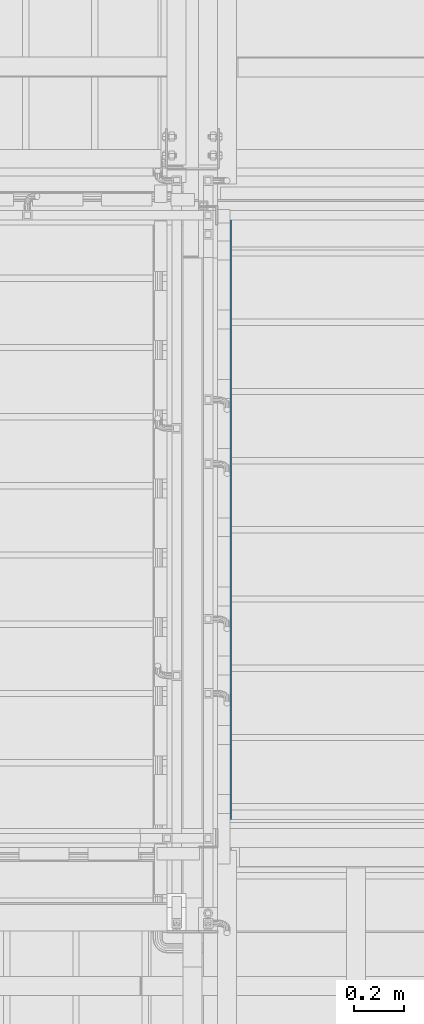
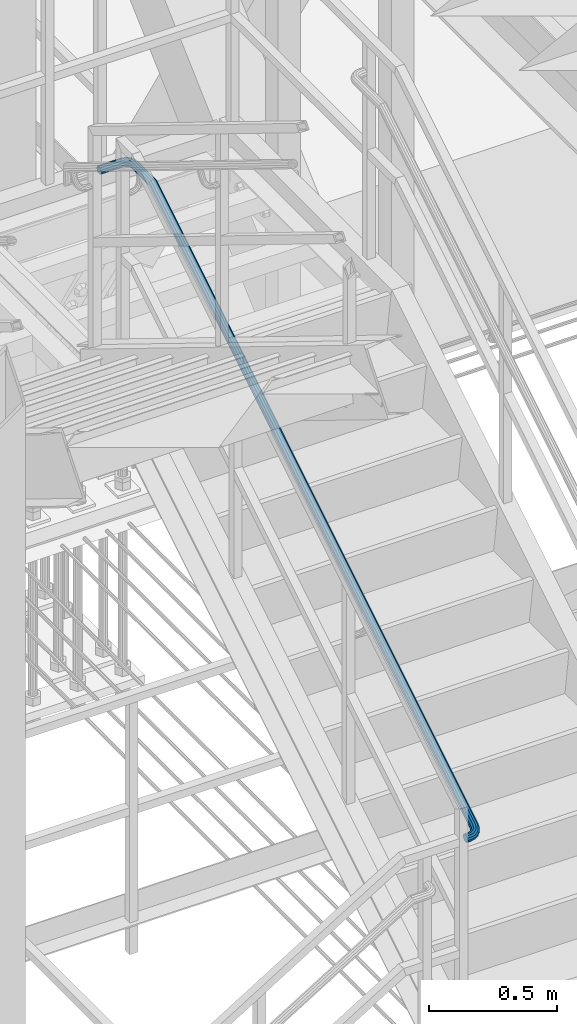
# One storey, part 1767 of 3843: 1 beam, 1 element without a shape of its own.
"""IFC2X3 building model written with IfcOpenShell, lengths in millimetres."""

import ifcopenshell
import ifcopenshell.guid

model = None  # the IFC model being written
_history = None  # IfcOwnerHistory: only IFC2X3 demands one
_inside = {}  # id of a spatial element -> (the spatial element, [elements in it])
_under = {}  # id of a project, library or spatial element -> (it, [spatial elements below it])
_declared = {}  # id of a project -> (the project, [libraries it declares])
_typed = {}  # id of a type object -> (the type object, [elements of that type])
_made_of = {}  # id of a material, layer set ... -> (it, [elements and type objects made of it])


def new_model(schema):
    """Start an empty IFC model of exactly this schema.

    Asked for "IFC4X3", IfcOpenShell would pick the latest addendum, in which some entities
    have other attributes; the version numbers below select the first issue.
    IFC2X3 requires an IfcOwnerHistory on every rooted entity: one is made here for all.
    """
    global model, _history
    if schema == "IFC4X3":
        model = ifcopenshell.file(schema_version=(4, 3, 0, 0))
    else:
        model = ifcopenshell.file(schema=schema)
    _inside.clear()
    _under.clear()
    _declared.clear()
    _typed.clear()
    _made_of.clear()
    _history = None
    if model.schema == "IFC2X3":
        org = make("IfcOrganization", Name="unknown")
        user = make(
            "IfcPersonAndOrganization",
            ThePerson=make("IfcPerson", FamilyName="unknown"),
            TheOrganization=org,
        )
        app = make(
            "IfcApplication",
            ApplicationDeveloper=org,
            Version="unknown",
            ApplicationFullName="unknown",
            ApplicationIdentifier="unknown",
        )
        _history = make(
            "IfcOwnerHistory",
            OwningUser=user,
            OwningApplication=app,
            ChangeAction="ADDED",
            CreationDate=0,
        )
    return model


def make(cls, **values):
    """One entity of the class cls with the attributes given. An attribute that is None is left unset."""
    return model.create_entity(
        cls, **{name: value for name, value in values.items() if value is not None}
    )


def rooted(cls, **values):
    """An entity with a GlobalId (a new one), such as an element, a storey or a relation."""
    return make(cls, GlobalId=ifcopenshell.guid.new(), OwnerHistory=_history, **values)


def si_unit(unit_type, name, prefix=None):
    """IfcSIUnit, for example si_unit("LENGTHUNIT", "METRE", prefix="MILLI")."""
    return make("IfcSIUnit", UnitType=unit_type, Prefix=prefix, Name=name)


def assignment(units):
    """IfcUnitAssignment: the units of a project."""
    return None if units is None else make("IfcUnitAssignment", Units=units)


def point(xyz):
    """IfcCartesianPoint."""
    return None if xyz is None else make("IfcCartesianPoint", Coordinates=xyz)


def direction(xyz):
    """IfcDirection."""
    return None if xyz is None else make("IfcDirection", DirectionRatios=xyz)


def frame(location, z_axis=None, x_axis=None):
    """IfcAxis2Placement3D, a coordinate frame: its origin and axes. An axis left out is left unset."""
    return make(
        "IfcAxis2Placement3D",
        Location=point(location),
        Axis=direction(z_axis),
        RefDirection=direction(x_axis),
    )


def origin_with_axes():
    """The frame at (0, 0, 0) with the z axis (0, 0, 1) and the x axis (1, 0, 0) written out."""
    return frame((0.0, 0.0, 0.0), z_axis=(0.0, 0.0, 1.0), x_axis=(1.0, 0.0, 0.0))


def place(relative_to, where):
    """IfcLocalPlacement: puts the frame where relative to a parent placement (None: the world)."""
    return make(
        "IfcLocalPlacement", PlacementRelTo=relative_to, RelativePlacement=where
    )


def context(
    kind, dimensions, precision=None, world=None, true_north=None, identifier=None
):
    """IfcGeometricRepresentationContext, for example the 3D "Model" context."""
    return make(
        "IfcGeometricRepresentationContext",
        ContextIdentifier=identifier,
        ContextType=kind,
        CoordinateSpaceDimension=dimensions,
        Precision=precision,
        WorldCoordinateSystem=world,
        TrueNorth=true_north,
    )


def subcontext(parent, identifier, kind, view, scale=None):
    """IfcGeometricRepresentationSubContext, for example "Body" below "Model"."""
    return make(
        "IfcGeometricRepresentationSubContext",
        ContextIdentifier=identifier,
        ContextType=kind,
        ParentContext=parent,
        TargetScale=scale,
        TargetView=view,
    )


def project(units=None, contexts=None):
    """IfcProject with its units and contexts."""
    return rooted(
        "IfcProject",
        Name="project",
        RepresentationContexts=contexts,
        UnitsInContext=assignment(units),
    )


def spatial(cls, under=None, at=None, **own):
    """A site, building, storey or space (cls), placed at a placement, below another one or the project."""
    s = rooted(cls, ObjectPlacement=at, **own)
    if under is not None:
        _under.setdefault(under.id(), (under, []))[1].append(s)
    return s


def faces_of(points, faces, orient=None, outer=None):
    """IfcFace entities. A face is a list of loops; a loop is a list of indices into points, from 0.

    orient and outer hold one flag for each loop. By default every Orientation is true, the
    first loop of a face is its IfcFaceOuterBound and the others are IfcFaceBound.
    """
    made = []
    for i, loops in enumerate(faces):
        bounds = []
        for j, loop in enumerate(loops):
            is_outer = j == 0 if outer is None else outer[i][j]
            bounds.append(
                make(
                    "IfcFaceOuterBound" if is_outer else "IfcFaceBound",
                    Bound=make("IfcPolyLoop", Polygon=[points[k] for k in loop]),
                    Orientation=True if orient is None else orient[i][j],
                )
            )
        made.append(make("IfcFace", Bounds=bounds))
    return made


def faceted_brep(points, faces, orient=None, outer=None, voids=None):
    """IfcFacetedBrep: a solid bounded by flat faces; with voids (closed shells), ...WithVoids."""
    shared = [point(p) for p in points]
    hull = make("IfcClosedShell", CfsFaces=faces_of(shared, faces, orient, outer))
    if voids is None:
        return make("IfcFacetedBrep", Outer=hull)
    return make(
        "IfcFacetedBrepWithVoids",
        Outer=hull,
        Voids=[
            make(cls, CfsFaces=faces_of(shared, fs, o, b)) for cls, fs, o, b in voids
        ],
    )


def shape(context_of_items, identifier, shape_type, items):
    """IfcShapeRepresentation: the items that make up one representation, for example the "Body"."""
    return make(
        "IfcShapeRepresentation",
        ContextOfItems=context_of_items,
        RepresentationIdentifier=identifier,
        RepresentationType=shape_type,
        Items=items,
    )


def material(Name=None, Category=None):
    """IfcMaterial."""
    return make("IfcMaterial", Name=Name, Category=Category)


def made_of(thing, what):
    """Note that an element or type object is made of a material, layer set ...; save() writes the relation."""
    if what is not None:
        _made_of.setdefault(what.id(), (what, []))[1].append(thing)
    return thing


def type_object(cls, material=None, **own):
    """A type object (cls), such as IfcWallType, which elements share."""
    return made_of(rooted(cls, **own), material)


def element(
    cls,
    number,
    at=None,
    inside=None,
    cuts=None,
    type_object=None,
    material=None,
    context=None,
    identifier="Body",
    shape_type=None,
    held_by="IfcProductDefinitionShape",
    body=None,
    shapes=None,
    **own,
):
    """One element of the class cls, such as IfcWall. Its Tag is "e" and its number.

    at: its placement. inside: the storey or other place that contains it. cuts: it is an
    opening in that element (IfcRelVoidsElement). A single representation is given by context,
    identifier, shape_type and body (its items); several are given by shapes. held_by: the class
    of the entity that holds the representations. save() writes the other relations.
    """
    e = rooted(cls, Tag="e%d" % number, ObjectPlacement=at, **own)
    if body is not None:
        shapes = [shape(context, identifier, shape_type, body)]
    if shapes is not None:
        e.Representation = make(held_by, Representations=shapes)
    if inside is not None:
        _inside.setdefault(inside.id(), (inside, []))[1].append(e)
    if cuts is not None:
        rooted(
            "IfcRelVoidsElement", RelatingBuildingElement=cuts, RelatedOpeningElement=e
        )
    if type_object is not None:
        _typed.setdefault(type_object.id(), (type_object, []))[1].append(e)
    return made_of(e, material)


def aggregate(whole, parts):
    """IfcRelAggregates: a whole, such as a stair, and the parts it consists of."""
    return rooted("IfcRelAggregates", RelatingObject=whole, RelatedObjects=parts)


def save(model, path):
    """Write the relations noted so far, then the file.

    IfcRelAggregates (storeys below a building ...), IfcRelContainedInSpatialStructure (elements
    in a storey), IfcRelDefinesByType, IfcRelAssociatesMaterial and IfcRelDeclares: one each for
    every whole, place, type object, material and project.
    """
    for whole, parts in _under.values():
        aggregate(whole, parts)
    for where, things in _inside.values():
        rooted(
            "IfcRelContainedInSpatialStructure",
            RelatedElements=things,
            RelatingStructure=where,
        )
    for kind, things in _typed.values():
        rooted("IfcRelDefinesByType", RelatedObjects=things, RelatingType=kind)
    for what, things in _made_of.values():
        rooted("IfcRelAssociatesMaterial", RelatedObjects=things, RelatingMaterial=what)
    for by, libraries in _declared.values():
        rooted("IfcRelDeclares", RelatingContext=by, RelatedDefinitions=libraries)
    model.write(path)


model = new_model("IFC2X3")

# Units and contexts
model_context = context("Model", 3, precision=1e-05, world=origin_with_axes())
body_context = subcontext(model_context, "Body", "Model", "MODEL_VIEW")
ifc_project = project(units=[si_unit("LENGTHUNIT", "METRE", prefix="MILLI"), si_unit("AREAUNIT", "SQUARE_METRE"), si_unit("VOLUMEUNIT", "CUBIC_METRE"), si_unit("MASSUNIT", "GRAM", prefix="KILO"), si_unit("TIMEUNIT", "SECOND"), si_unit("PLANEANGLEUNIT", "RADIAN"), si_unit("SOLIDANGLEUNIT", "STERADIAN"), si_unit("THERMODYNAMICTEMPERATUREUNIT", "DEGREE_CELSIUS"), si_unit("LUMINOUSINTENSITYUNIT", "LUMEN")], contexts=[model_context])

# Site, building, storey
site_placement = place(None, origin_with_axes())
site = spatial("IfcSite", under=ifc_project, at=site_placement, CompositionType="ELEMENT")
building_placement = place(site_placement, origin_with_axes())
building = spatial("IfcBuilding", under=site, at=building_placement, Name="Undefined", CompositionType="ELEMENT")
storey_placement = place(building_placement, origin_with_axes())
storey = spatial("IfcBuildingStorey", under=building, at=storey_placement, Name="Undefined", CompositionType="ELEMENT", Elevation=0.0)

# Assembly, beam
assembly_placement = place(storey_placement, origin_with_axes())
assembly = element("IfcElementAssembly", 1, at=assembly_placement, inside=storey, Name="RAIL", AssemblyPlace="NOTDEFINED", PredefinedType="RIGID_FRAME")
ifc_material = material(Name="STEEL/A513")
beam_type = type_object("IfcBeamType", PredefinedType="NOTDEFINED")
beam_placement = place(assembly_placement, frame((54463.95, 19202.4000001452, 32402.584613986), z_axis=(0.0, 0.0, 1.0), x_axis=(1.0, 0.0, 0.0)))
beam = element("IfcBeam", 2, at=beam_placement, type_object=beam_type, material=ifc_material, Name="GRAB RAIL", context=body_context, shape_type="Brep", body=[
    faceted_brep([(0.0, -19.0500000000029, 0.0), (0.0, -16.4977839420972, -9.52500000000146), (19.0500015258804, -16.4977839420972, -9.52500000000146), (19.0500015258804, -19.0500000000029, 0.0), (0.0, -9.52500000000146, -16.4977839420972), (19.0500015258804, -9.52500000000146, -16.4977839420972), (0.0, 0.0, -19.0499989999989), (19.0500015258804, 0.0, -19.0500000000029), (0.0, 9.52500000000146, -16.4977839420972), (19.0500015258804, 9.52500000000146, -16.4977839420972), (0.0, 16.4977839420972, -9.52500000000146), (19.0500015258804, 16.4977839420972, -9.52500000000146), (0.0, 19.0500000000029, 0.0), (19.0500015258804, 19.0500000000029, 0.0), (0.0, 16.4977839420972, 9.52500000000146), (19.0500015258804, 16.4977839420972, 9.52500000000146), (0.0, 9.52500000000146, 16.4977839420972), (19.0500015258804, 9.52500000000146, 16.4977839420972), (0.0, 0.0, 19.0499989999989), (19.0500015258804, 0.0, 19.0500000000029), (0.0, -9.52500000000146, 16.4977839420972), (19.0500015258804, -9.52500000000146, 16.4977839420972), (0.0, -16.4977839420972, 9.52500000000146), (19.0500015258804, -16.4977839420972, 9.52500000000146), (0.0, -15.875, 0.0), (0.0, -13.7481532850798, 7.9375), (19.0500015258804, -13.7481532850798, 7.9375), (19.0500015258804, -15.875, 0.0), (0.0, -7.9375, 13.7481532850798), (19.0500015258804, -7.9375, 13.7481532850798), (0.0, 0.0, 15.875), (19.0500015258804, 0.0, 15.875), (0.0, 7.9375, 13.7481532850798), (19.0500015258804, 7.9375, 13.7481532850798), (0.0, 13.7481532850798, 7.9375), (19.0500015258804, 13.7481532850798, 7.9375), (0.0, 15.875, 0.0), (19.0500015258804, 15.875, 0.0), (0.0, 13.7481532850798, -7.9375), (19.0500015258804, 13.7481532850798, -7.9375), (0.0, 7.9375, -13.7481532850798), (19.0500015258804, 7.9375, -13.7481532850798), (0.0, 0.0, -15.875), (19.0500015258804, 0.0, -15.875), (0.0, -7.9375, -13.7481532850798), (19.0500015258804, -7.9375, -13.7481532850798), (0.0, -13.7481532850798, -7.9375), (19.0500015258804, -13.7481532850798, -7.9375), (35.8370683576213, -16.785602193122, 1.39347557251313), (33.6227625831598, -14.5320725698184, 10.7346685359589), (30.658409666401, -7.95914849072506, 17.4613848702174), (27.7383055774699, 1.17196034525477, 19.7712063658182), (25.6448898488088, 10.4145806995184, 17.0452182183471), (24.9390915343392, 17.2921599121983, 10.0138467504985), (25.8100287224443, 19.9618561873722, 0.56114226876889), (28.0243344969058, 17.7083265640686, -8.7800506946769), (30.9886874136646, 11.1354024849788, -15.5067670289391), (33.9087915025957, 2.00429364899537, -17.8165885245362), (36.0022072312495, -7.23832670526826, -15.0906003770651), (36.7080055457191, -14.1159059179481, -8.05922890922011), (35.7272627114362, -11.4985670987699, -6.55313927090901), (35.1390974493843, -5.76725108820392, -12.412615494115), (33.3945843421679, 1.93493254035275, -14.6842722836736), (30.9611642680611, 9.54418990366685, -12.7594210373427), (28.4908701707609, 15.0216266362477, -7.15382409212543), (26.645615358706, 16.8995679889958, 0.630503377415152), (25.9198343686221, 14.67482109302, 8.50775711219103), (26.5079996306813, 8.94350508245407, 14.367233335397), (28.2525127378976, 1.2413214538974, 16.6388901249557), (30.6859328120045, -6.3679359094167, 14.7140388786211), (33.1562269093047, -11.8453726419939, 9.10844193340381), (35.0014817213523, -13.7233139947457, 1.32411446386686), (47.3130995891261, 7.82098036889511, -14.2370890070451), (51.2950129292367, -0.602142335348617, -11.0067946137497), (41.758731545051, 15.8089725243517, -12.6307239297494), (36.1201972288836, 21.221458083819, -6.618123607077), (31.9083373571411, 22.6081659125957, 2.18964056010009), (30.2517163810844, 19.5975287678193, 11.4325352760679), (31.594224553417, 12.9962444411394, 18.6339343659492), (35.5761378935276, 4.5731217368957, 21.8642287592447), (41.1305059376027, -3.41487041856089, 20.2578636819526), (46.7690402537701, -8.82735597802821, 14.2452633592802), (50.9809001255198, -10.2140638068013, 5.43749919210313), (52.6375211015693, -7.20342666202851, -3.80539552386472), (49.3915198948162, -7.47887799685486, 5.16684430610258), (50.7720373748598, -4.9700137095424, -2.53556795720215), (45.8816366683604, -6.32328813954155, 12.5066477787514), (41.1828580715519, -1.81288350664909, 17.517148047642), (36.5542180348275, 4.84377662289626, 18.8557856120533), (33.2359569180626, 11.8630455430975, 16.1638736176428), (32.1172001077866, 17.3641158153332, 10.1627077094054), (33.4977175878375, 19.8729801026457, 2.46029544610064), (37.0076008142933, 18.7173902453324, -4.87950802654814), (41.7063794110945, 14.2069856124399, -9.89000829544239), (46.3350194478262, 7.55032548289455, -11.2286458598537), (49.6532805645911, 0.531056562696904, -8.5367338654396), (57.950818716643, 16.8806823363084, -8.66188780013181), (63.4314522468558, 9.7339571466182, -4.64611801380306), (50.3058869611341, 23.0882285199878, -8.1511817816463), (42.5451102704028, 26.6932887107578, -3.25084322356633), (36.7479824913753, 26.7298899418383, 4.72608611482792), (34.4678393308568, 23.1882249429182, 13.642194459233), (36.3156433073382, 17.0172799903194, 21.1084177791417), (41.796276837551, 9.87055480062918, 25.1241875654705), (49.4412085930599, 3.66300861694981, 24.6134815469813), (57.2019852837911, 0.0579484261797916, 19.713142988905), (62.9991130628187, 0.0213471950992243, 11.7362136505108), (65.2792562233371, 3.56301219401939, 2.82010530610205), (60.8115188485317, 2.2470590906596, 11.1520363558702), (62.7116381489614, 5.19844658976217, 3.72194606886478), (55.9805790326791, 2.27756011655947, 17.7994774711988), (49.5132651237363, 5.28177694220358, 21.883092936263), (43.1424886608074, 10.4547320952697, 22.3086812850015), (38.5752940523016, 16.4103364200128, 18.9622064630639), (37.0354574052326, 21.5527905471754, 12.7403536964739), (38.9355767056622, 24.504178046278, 5.31026340946846), (43.7665165215221, 24.4736770203781, -1.33717770586009), (50.2338304304576, 21.469460194734, -5.42079317092794), (56.6046068933865, 16.2965050416678, -5.84638151966647), (61.1718015018923, 10.3409007169248, -2.49990669772524), (64.7806548195949, 28.296572800009, -1.63672444265103), (71.2235259441441, 22.7582023074901, 3.3688020797199), (55.7934985382453, 32.2606261774745, -2.5066293808959), (46.6701583679605, 33.5881975386365, 0.992177590691426), (39.8552259396238, 31.9235652093812, 7.92219396959263), (37.1747568938881, 27.7127660780243, 16.4265274635509), (39.3469807468937, 22.0840803713036, 24.2264487806933), (45.7898518714501, 16.5457098787811, 29.2319753030679), (54.7770081527924, 12.5816565013192, 30.1018802413091), (63.9003483230845, 11.2540851401573, 26.6030732697254), (70.7152807514212, 12.9187174694125, 19.6730568908242), (73.3957497971569, 17.1295166007694, 11.1687233968623), (68.1436095171011, 14.5024547810754, 18.6938183140519), (70.3773337218809, 18.0114540572067, 11.6068737357564), (62.4644991601599, 13.1152611733633, 24.4688319631387), (54.8617156849141, 14.2215706409988, 27.3845044394584), (47.3724187837943, 17.5249484555534, 26.6595836575907), (42.0033595133282, 22.1402571993167, 22.4883115556113), (40.1931729691569, 26.8308286215834, 15.9883771246605), (42.4268971739366, 30.3398278977147, 8.90143254636132), (48.1060075308851, 31.7270215054305, 3.12641889727456), (55.7087910061309, 30.6207120377949, 0.21074642095482), (63.1980879072435, 27.3173342232403, 0.935667202822515), (68.5671471777096, 22.702025479477, 5.10693930480193), (73.9084915570638, 37.1956892856761, 12.2534094448456), (76.1925028810874, 32.1681025835023, 20.4232378414599), (67.1340559539531, 40.9511848622315, 6.15072912878168), (57.6844006207975, 42.428307306247, 3.75040515561705), (48.0915530728598, 41.2312628517284, 5.69560239553539), (40.9259090637279, 37.6807985935702, 11.4651068189814), (38.1074971189009, 32.7282585624998, 19.5129843749673), (40.3915084429245, 27.7006718603261, 27.682812771578), (47.1659440460353, 23.9451762837743, 33.785493087642), (56.6155993791908, 22.4680538397588, 36.1858170608066), (66.2084469271285, 23.6650982942738, 34.2406198208882), (73.3740909362605, 27.2155625524319, 28.4711153974422), (70.6700757802173, 28.0876655558604, 27.0539480159059), (73.0187524009089, 32.2147822484185, 20.3473833859171), (64.6987057726074, 25.1289453407298, 31.8618683687782), (56.7046661493223, 24.1314082952995, 33.482866068709), (48.8299533716927, 25.3623436653106, 31.4825960910712), (43.1845903691064, 28.4919233124383, 26.3970291610167), (41.2812475990795, 32.6815788975837, 19.5888388305066), (43.6299242197711, 36.8086955901417, 12.8822742005214), (49.601294227381, 39.7674158052723, 8.07435384764904), (57.5953338506661, 40.7649528507063, 6.45335614771466), (65.4700466282957, 39.5340174806915, 8.45362612535246), (71.1154096308819, 36.4044378335639, 13.5391930554069), (76.1925028810874, 2547.40379899487, 1568.26058842233), (73.3740909362605, 2542.4512589638, 1576.30846597832), (73.9084915570638, 2552.43138569705, 1560.09076002572), (67.1340559539531, 2556.1868812736, 1553.98807970965), (57.6844006207975, 2557.66400371762, 1551.58775573648), (48.0915530728598, 2556.4669592631, 1553.5329529764), (40.9259090637279, 2552.91649500494, 1559.30245739985), (38.1074971189009, 2547.96395497387, 1567.35033495583), (40.3915084429245, 2542.9363682717, 1575.52016335244), (47.1659440460353, 2539.18087269515, 1581.62284366852), (56.6155993791908, 2537.70375025113, 1584.02316764168), (66.2084469271285, 2538.90079470565, 1582.07797040176), (64.6987057726074, 2540.3646417521, 1579.69921894965), (70.6700757802173, 2543.32336196723, 1574.89129859677), (56.7046661493223, 2539.36710470667, 1581.32021664958), (48.8299533716927, 2540.59804007669, 1579.31994667194), (43.1845903691064, 2543.72761972381, 1574.23437974188), (41.2812475990795, 2547.91727530896, 1567.42618941138), (43.6299242197711, 2552.04439200151, 1560.71962478139), (49.601294227381, 2555.00311221665, 1555.91170442852), (57.5953338506661, 2556.00064926207, 1554.29070672859), (65.4700466282957, 2554.76971389206, 1556.29097670623), (71.1154096308819, 2551.64013424494, 1561.37654363628), (73.0187524009089, 2547.45047865979, 1568.18473396679), (76.1925028810874, 2552.54874323262, 1571.42670795109), (73.3740909362605, 2549.87409209101, 1580.87636328425), (73.9084915570638, 2555.26392381231, 1561.83386040316), (67.1340559539531, 2557.29210338645, 1554.66821639402), (57.6844006207975, 2558.08983287605, 1551.84980444919), (48.0915530728598, 2557.44336130858, 1554.13381577321), (40.9259090637279, 2555.52591021849, 1560.90825137632), (38.1074971189009, 2552.85125907688, 1570.35790670948), (40.3915084429245, 2550.13607849719, 1579.95075425741), (47.1659440460353, 2548.10789892304, 1587.11639826654), (56.6155993791908, 2547.31016943345, 1589.93481021138), (66.2084469271285, 2547.95664100092, 1587.65079888735), (64.6987057726074, 2548.74720102656, 1584.85771696117), (70.6700757802173, 2550.34507693497, 1579.21235395858), (56.7046661493223, 2548.20847472033, 1586.7610597312), (48.8299533716927, 2548.873249295, 1584.4123831105), (43.1845903691064, 2550.56339894011, 1578.44101310289), (41.2812475990795, 2552.82604942319, 1570.44697347961), (43.6299242197711, 2555.05492537453, 1562.57226070198), (49.601294227381, 2556.65280128294, 1556.9268976994), (57.5953338506661, 2557.19152758917, 1555.02355492937), (65.4700466282957, 2556.5267530145, 1557.37223155007), (71.1154096308819, 2554.83660336939, 1563.34360155768), (73.0187524009089, 2552.57395288631, 1571.33764118095), (76.1925028810874, 2558.58983287605, 1571.42670795109), (73.3740909362605, 2558.58983287605, 1580.87636328425), (73.9084915570638, 2558.58983287605, 1561.83386040316), (67.1340559539603, 2558.58983287605, 1554.66821639402), (57.6844006207975, 2558.58983287605, 1551.84980444919), (48.0915530728598, 2558.58983287605, 1554.13381577321), (40.9259090637279, 2558.58983287605, 1560.90825137632), (38.1074971189009, 2558.58983287605, 1570.35790670947), (40.3915084429245, 2558.58983287605, 1579.95075425741), (47.165944046028, 2558.58983287605, 1587.11639826654), (56.6155993791908, 2558.58983287605, 1589.93481021138), (66.2084469271285, 2558.58983287605, 1587.65079888735), (64.6987057726001, 2558.58983287605, 1584.85771696118), (70.67007578021, 2558.58983287605, 1579.21235395858), (56.7046661493223, 2558.58983287605, 1586.7610597312), (48.8299533716927, 2558.58983287605, 1584.4123831105), (43.1845903691064, 2558.58983287605, 1578.44101310289), (41.2812475990795, 2558.58983287605, 1570.44697347961), (43.6299242197783, 2558.58983287605, 1562.57226070198), (49.6012942273883, 2558.58983287605, 1556.92689769939), (57.5953338506661, 2558.58983287605, 1555.02355492937), (65.4700466282957, 2558.58983287605, 1557.37223155007), (71.1154096308819, 2558.58983287605, 1563.34360155768), (73.0187524009089, 2558.58983287605, 1571.33764118095), (76.1925028810874, 2692.40000138069, 1571.42670795109), (73.3740909362605, 2692.40000138069, 1580.87636328425), (73.9084915570638, 2692.40000138069, 1561.83386040316), (67.1340559539603, 2692.40000138069, 1554.66821639402), (57.6844006207975, 2692.40000138069, 1551.84980444919), (48.0915530728598, 2692.40000138069, 1554.13381577321), (40.9259090637279, 2692.40000138069, 1560.90825137632), (38.1074971189009, 2692.40000138069, 1570.35790670947), (40.3915084429245, 2692.40000138069, 1579.95075425741), (47.165944046028, 2692.40000138069, 1587.11639826654), (56.6155993791908, 2692.40000138069, 1589.93481021138), (66.2084469271285, 2692.40000138069, 1587.65079888735), (64.6987057726001, 2692.40000138069, 1584.85771696118), (70.6700757802173, 2692.40000138069, 1579.21235395858), (56.7046661493223, 2692.40000138069, 1586.7610597312), (48.8299533716927, 2692.40000138069, 1584.4123831105), (43.1845903691064, 2692.40000138069, 1578.44101310289), (41.2812475990795, 2692.40000138069, 1570.44697347961), (43.6299242197783, 2692.40000138069, 1562.57226070198), (49.6012942273883, 2692.40000138069, 1556.92689769939), (57.5953338506661, 2692.40000138069, 1555.02355492937), (65.4700466282957, 2692.40000138069, 1557.37223155007), (71.1154096308819, 2692.40000138069, 1563.34360155768), (73.0187524009089, 2692.40000138069, 1571.33764118095), (70.7152807514212, 2709.18706821246, 1580.87636328424), (63.9003483230917, 2706.97276243799, 1587.65079888735), (54.7770081527997, 2704.00840952123, 1589.93481021138), (45.7898518714501, 2701.0883054323, 1587.11639826654), (39.3469807468937, 2698.99488970364, 1579.95075425741), (37.1747568938881, 2698.28909138917, 1570.35790670948), (39.8552259396238, 2699.16002857727, 1560.90825137632), (46.6701583679533, 2701.37433435173, 1554.13381577321), (55.7934985382453, 2704.3386872685, 1551.84980444919), (64.7806548195877, 2707.25879135743, 1554.66821639402), (71.2235259441441, 2709.35220708609, 1561.83386040316), (73.3957497971569, 2710.05800540056, 1571.42670795109), (70.3773337218809, 2709.07726256628, 1571.33764118095), (68.5671471777096, 2708.48909730422, 1563.34360155768), (63.1980879072435, 2706.744584197, 1557.37223155007), (55.7087910061236, 2704.31116412289, 1555.02355492938), (48.1060075308851, 2701.84087002559, 1556.9268976994), (42.4268971739366, 2699.99561521353, 1562.57226070198), (40.1931729691569, 2699.26983422345, 1570.44697347961), (42.0033595133355, 2699.85799948551, 1578.44101310289), (47.3724187838015, 2701.60251259273, 1584.4123831105), (54.8617156849214, 2704.03593266684, 1586.76105973119), (62.4644991601599, 2706.50622676414, 1584.85771696117), (68.1436095171084, 2708.35148157619, 1579.21235395858), (57.9508187166357, 2720.66309944397, 1554.66821639402), (63.4314522468485, 2724.64501278408, 1561.83386040315), (50.3058869611268, 2715.10873139989, 1551.84980444919), (42.5451102703955, 2709.47019708372, 1554.13381577322), (36.747982491368, 2705.25833721197, 1560.90825137632), (34.4678393308568, 2703.60171623591, 1570.35790670948), (36.3156433073382, 2704.94422440825, 1579.95075425741), (41.796276837551, 2708.92613774836, 1587.11639826654), (49.4412085930671, 2714.48050579244, 1589.93481021138), (57.2019852837911, 2720.11904010861, 1587.65079888735), (62.9991130628187, 2724.33089998036, 1580.87636328424), (65.2792562233299, 2725.98752095642, 1571.42670795109), (60.8115188485317, 2722.74151974966, 1579.21235395858), (62.7116381489614, 2724.12203722971, 1571.33764118095), (55.9805790326718, 2719.2316365232, 1584.85771696117), (49.5132651237363, 2714.5328579264, 1586.76105973119), (43.1424886608074, 2709.90421788966, 1584.4123831105), (38.5752940523016, 2706.5859567729, 1578.44101310289), (37.0354574052253, 2705.46719996262, 1570.44697347961), (38.935576705655, 2706.84771744267, 1562.57226070198), (43.7665165215149, 2710.35760066913, 1556.9268976994), (50.2338304304503, 2715.05637926593, 1555.02355492938), (56.6046068933792, 2719.68501930267, 1557.37223155006), (61.1718015018851, 2723.00328041943, 1563.34360155767), (47.3130995891261, 2731.30081857148, 1554.66821639402), (51.295012929244, 2736.78145210169, 1561.83386040315), (41.758731545051, 2723.65588681596, 1551.84980444919), (36.1201972288836, 2715.89511012523, 1554.13381577322), (31.9083373571411, 2710.0979823462, 1560.90825137632), (30.2517163810844, 2707.81783918569, 1570.35790670948), (31.594224553417, 2709.66564316217, 1579.95075425742), (35.5761378935349, 2715.14627669239, 1587.11639826654), (41.13050593761, 2722.7912084479, 1589.93481021137), (46.7690402537773, 2730.55198513863, 1587.65079888735), (50.9809001255198, 2736.34911291766, 1580.87636328424), (52.6375211015766, 2738.62925607817, 1571.42670795108), (49.3915198948234, 2734.16151870337, 1579.21235395858), (50.7720373748671, 2736.0616380038, 1571.33764118095), (45.8816366683677, 2729.33057888752, 1584.85771696117), (41.1828580715664, 2722.86326497857, 1586.76105973119), (36.5542180348348, 2716.49248851564, 1584.4123831105), (33.2359569180699, 2711.92529390713, 1578.44101310289), (32.1172001077939, 2710.38545726006, 1570.44697347961), (33.4977175878375, 2712.28557656049, 1562.57226070198), (37.0076008142933, 2717.11651637635, 1556.9268976994), (41.7063794110945, 2723.58383028529, 1555.02355492937), (46.3350194478262, 2729.95460674822, 1557.37223155006), (49.6532805645911, 2734.52180135673, 1563.34360155767), (33.9087915025957, 2738.13065467443, 1554.66821639402), (36.0022072312495, 2744.57352579899, 1561.83386040315), (30.9886874136646, 2729.14349839308, 1551.84980444919), (28.0243344968985, 2720.02015822279, 1554.13381577322), (25.8100287224443, 2713.20522579446, 1560.90825137632), (24.9390915343392, 2710.52475674872, 1570.35790670948), (25.6448898488088, 2712.69698060174, 1579.95075425742), (27.7383055774699, 2719.1398517263, 1587.11639826654), (30.658409666401, 2728.12700800764, 1589.93481021137), (33.6227625831598, 2737.25034817793, 1587.65079888735), (35.8370683576213, 2744.06528060627, 1580.87636328423), (36.7080055457263, 2746.745749652, 1571.42670795108), (35.0014817213596, 2741.49360937196, 1579.21235395858), (35.7272627114435, 2743.72733357673, 1571.33764118095), (33.1562269093047, 2735.81449901501, 1584.85771696116), (30.6859328120117, 2728.21171553976, 1586.76105973119), (28.2525127378976, 2720.72241863864, 1584.4123831105), (26.5079996306813, 2715.35335936818, 1578.44101310289), (25.9198343686221, 2713.543172824, 1570.44697347961), (26.645615358706, 2715.77689702877, 1562.57226070198), (28.4908701707536, 2721.45600738572, 1556.9268976994), (30.9611642680538, 2729.05879086096, 1555.02355492937), (33.3945843421679, 2736.54808776209, 1557.37223155006), (35.1390974493843, 2741.91714703255, 1563.34360155767), (19.0500015258585, 2747.25849141191, 1561.83386040314), (19.0500015258585, 2749.54250273594, 1571.42670795108), (19.0500015258585, 2740.4840558088, 1554.66821639402), (19.0500015258658, 2731.03440047563, 1551.84980444919), (19.0500015258658, 2721.4415529277, 1554.13381577322), (19.0500015258658, 2714.27590891857, 1560.90825137632), (19.0500015258658, 2711.45749697374, 1570.35790670948), (19.0500015258658, 2713.74150829777, 1579.95075425742), (19.0500015258658, 2720.51594390089, 1587.11639826654), (19.0500015258658, 2729.96559923405, 1589.93481021137), (19.0500015258658, 2739.55844678199, 1587.65079888735), (19.0500015258731, 2746.72409079108, 1580.87636328424), (19.0500015258731, 2744.02007563504, 1579.21235395858), (19.0500015258585, 2746.36875225576, 1571.33764118095), (19.0500015258658, 2738.04870562746, 1584.85771696116), (19.0500015258658, 2730.05466600418, 1586.76105973119), (19.0500015258658, 2722.17995322654, 1584.4123831105), (19.0500015258658, 2716.53459022395, 1578.4410131029), (19.0500015258658, 2714.63124745392, 1570.44697347961), (19.0500015258658, 2716.97992407461, 1562.57226070198), (19.0500015258658, 2722.95129408222, 1556.9268976994), (19.0500015258658, 2730.9453337055, 1555.02355492937), (19.0500015258585, 2738.82004648314, 1557.37223155006), (19.0500015258585, 2744.46540948573, 1563.34360155767), (-82.5500000000029, 2749.54250273591, 1571.42670795109), (-82.5500000000029, 2746.72409079108, 1580.87636328424), (-82.5500000000029, 2747.25849141188, 1561.83386040315), (-82.5500000000029, 2740.48405580877, 1554.66821639402), (-82.5500000000029, 2731.03440047562, 1551.84980444919), (-82.5500000000029, 2721.44155292768, 1554.13381577322), (-82.5500000000029, 2714.27590891855, 1560.90825137632), (-82.5500000000029, 2711.45749697372, 1570.35790670948), (-82.5500000000029, 2713.74150829774, 1579.95075425742), (-82.5500000000029, 2720.51594390085, 1587.11639826654), (-82.5500000000029, 2729.96559923401, 1589.93481021138), (-82.5500000000029, 2739.55844678195, 1587.65079888735), (-82.5500000000029, 2738.04870562743, 1584.85771696117), (-82.5500000000029, 2744.02007563504, 1579.21235395858), (-82.5500000000029, 2730.05466600414, 1586.76105973119), (-82.5500000000029, 2722.17995322651, 1584.4123831105), (-82.5500000000029, 2716.53459022392, 1578.44101310289), (-82.5500000000029, 2714.6312474539, 1570.44697347961), (-82.5500000000029, 2716.97992407459, 1562.57226070198), (-82.5500000000029, 2722.9512940822, 1556.9268976994), (-82.5500000000029, 2730.94533370548, 1555.02355492938), (-82.5500000000029, 2738.82004648311, 1557.37223155007), (-82.5500000000029, 2744.4654094857, 1563.34360155768), (-82.5500000000029, 2746.36875225572, 1571.33764118095)], [[[0, 1, 2, 3]], [[1, 4, 5, 2]], [[4, 6, 7, 5]], [[6, 8, 9, 7]], [[8, 10, 11, 9]], [[10, 12, 13, 11]], [[12, 14, 15, 13]], [[14, 16, 17, 15]], [[16, 18, 19, 17]], [[18, 20, 21, 19]], [[20, 22, 23, 21]], [[22, 0, 3, 23]], [[24, 25, 26, 27]], [[25, 28, 29, 26]], [[28, 30, 31, 29]], [[30, 32, 33, 31]], [[32, 34, 35, 33]], [[34, 36, 37, 35]], [[36, 38, 39, 37]], [[38, 40, 41, 39]], [[40, 42, 43, 41]], [[42, 44, 45, 43]], [[44, 46, 47, 45]], [[46, 24, 27, 47]], [[22, 20, 18, 16, 14, 12, 10, 8, 6, 4, 1, 0], [46, 44, 42, 40, 38, 36, 34, 32, 30, 28, 25, 24]], [[23, 3, 48, 49]], [[21, 23, 49, 50]], [[19, 21, 50, 51]], [[17, 19, 51, 52]], [[15, 17, 52, 53]], [[13, 15, 53, 54]], [[11, 13, 54, 55]], [[9, 11, 55, 56]], [[7, 9, 56, 57]], [[5, 7, 57, 58]], [[2, 5, 58, 59]], [[3, 2, 59, 48]], [[45, 47, 60, 61]], [[43, 45, 61, 62]], [[41, 43, 62, 63]], [[39, 41, 63, 64]], [[37, 39, 64, 65]], [[35, 37, 65, 66]], [[33, 35, 66, 67]], [[31, 33, 67, 68]], [[29, 31, 68, 69]], [[26, 29, 69, 70]], [[27, 26, 70, 71]], [[47, 27, 71, 60]], [[57, 72, 73, 58]], [[56, 74, 72, 57]], [[55, 75, 74, 56]], [[54, 76, 75, 55]], [[53, 77, 76, 54]], [[52, 78, 77, 53]], [[51, 79, 78, 52]], [[50, 80, 79, 51]], [[49, 81, 80, 50]], [[48, 82, 81, 49]], [[59, 83, 82, 48]], [[58, 73, 83, 59]], [[71, 84, 85, 60]], [[70, 86, 84, 71]], [[69, 87, 86, 70]], [[68, 88, 87, 69]], [[67, 89, 88, 68]], [[66, 90, 89, 67]], [[65, 91, 90, 66]], [[64, 92, 91, 65]], [[63, 93, 92, 64]], [[62, 94, 93, 63]], [[61, 95, 94, 62]], [[60, 85, 95, 61]], [[72, 96, 97, 73]], [[74, 98, 96, 72]], [[75, 99, 98, 74]], [[76, 100, 99, 75]], [[77, 101, 100, 76]], [[78, 102, 101, 77]], [[79, 103, 102, 78]], [[80, 104, 103, 79]], [[81, 105, 104, 80]], [[82, 106, 105, 81]], [[83, 107, 106, 82]], [[73, 97, 107, 83]], [[84, 108, 109, 85]], [[86, 110, 108, 84]], [[87, 111, 110, 86]], [[88, 112, 111, 87]], [[89, 113, 112, 88]], [[90, 114, 113, 89]], [[91, 115, 114, 90]], [[92, 116, 115, 91]], [[93, 117, 116, 92]], [[94, 118, 117, 93]], [[95, 119, 118, 94]], [[85, 109, 119, 95]], [[96, 120, 121, 97]], [[98, 122, 120, 96]], [[99, 123, 122, 98]], [[100, 124, 123, 99]], [[101, 125, 124, 100]], [[102, 126, 125, 101]], [[103, 127, 126, 102]], [[104, 128, 127, 103]], [[105, 129, 128, 104]], [[106, 130, 129, 105]], [[107, 131, 130, 106]], [[97, 121, 131, 107]], [[108, 132, 133, 109]], [[110, 134, 132, 108]], [[111, 135, 134, 110]], [[112, 136, 135, 111]], [[113, 137, 136, 112]], [[114, 138, 137, 113]], [[115, 139, 138, 114]], [[116, 140, 139, 115]], [[117, 141, 140, 116]], [[118, 142, 141, 117]], [[119, 143, 142, 118]], [[109, 133, 143, 119]], [[121, 144, 145, 131]], [[120, 146, 144, 121]], [[122, 147, 146, 120]], [[123, 148, 147, 122]], [[124, 149, 148, 123]], [[125, 150, 149, 124]], [[126, 151, 150, 125]], [[127, 152, 151, 126]], [[128, 153, 152, 127]], [[129, 154, 153, 128]], [[130, 155, 154, 129]], [[131, 145, 155, 130]], [[132, 156, 157, 133]], [[134, 158, 156, 132]], [[135, 159, 158, 134]], [[136, 160, 159, 135]], [[137, 161, 160, 136]], [[138, 162, 161, 137]], [[139, 163, 162, 138]], [[140, 164, 163, 139]], [[141, 165, 164, 140]], [[142, 166, 165, 141]], [[143, 167, 166, 142]], [[133, 157, 167, 143]], [[155, 145, 168, 169]], [[145, 144, 170, 168]], [[144, 146, 171, 170]], [[146, 147, 172, 171]], [[147, 148, 173, 172]], [[148, 149, 174, 173]], [[149, 150, 175, 174]], [[150, 151, 176, 175]], [[151, 152, 177, 176]], [[152, 153, 178, 177]], [[153, 154, 179, 178]], [[154, 155, 169, 179]], [[156, 158, 180, 181]], [[158, 159, 182, 180]], [[159, 160, 183, 182]], [[160, 161, 184, 183]], [[161, 162, 185, 184]], [[162, 163, 186, 185]], [[163, 164, 187, 186]], [[164, 165, 188, 187]], [[165, 166, 189, 188]], [[166, 167, 190, 189]], [[167, 157, 191, 190]], [[157, 156, 181, 191]], [[169, 168, 192, 193]], [[168, 170, 194, 192]], [[170, 171, 195, 194]], [[171, 172, 196, 195]], [[172, 173, 197, 196]], [[173, 174, 198, 197]], [[174, 175, 199, 198]], [[175, 176, 200, 199]], [[176, 177, 201, 200]], [[177, 178, 202, 201]], [[178, 179, 203, 202]], [[179, 169, 193, 203]], [[181, 180, 204, 205]], [[180, 182, 206, 204]], [[182, 183, 207, 206]], [[183, 184, 208, 207]], [[184, 185, 209, 208]], [[185, 186, 210, 209]], [[186, 187, 211, 210]], [[187, 188, 212, 211]], [[188, 189, 213, 212]], [[189, 190, 214, 213]], [[190, 191, 215, 214]], [[191, 181, 205, 215]], [[193, 192, 216, 217]], [[192, 194, 218, 216]], [[194, 195, 219, 218]], [[195, 196, 220, 219]], [[196, 197, 221, 220]], [[197, 198, 222, 221]], [[198, 199, 223, 222]], [[199, 200, 224, 223]], [[200, 201, 225, 224]], [[201, 202, 226, 225]], [[202, 203, 227, 226]], [[203, 193, 217, 227]], [[205, 204, 228, 229]], [[204, 206, 230, 228]], [[206, 207, 231, 230]], [[207, 208, 232, 231]], [[208, 209, 233, 232]], [[209, 210, 234, 233]], [[210, 211, 235, 234]], [[211, 212, 236, 235]], [[212, 213, 237, 236]], [[213, 214, 238, 237]], [[214, 215, 239, 238]], [[215, 205, 229, 239]], [[217, 216, 240, 241]], [[216, 218, 242, 240]], [[218, 219, 243, 242]], [[219, 220, 244, 243]], [[220, 221, 245, 244]], [[221, 222, 246, 245]], [[222, 223, 247, 246]], [[223, 224, 248, 247]], [[224, 225, 249, 248]], [[225, 226, 250, 249]], [[226, 227, 251, 250]], [[227, 217, 241, 251]], [[229, 228, 252, 253]], [[228, 230, 254, 252]], [[230, 231, 255, 254]], [[231, 232, 256, 255]], [[232, 233, 257, 256]], [[233, 234, 258, 257]], [[234, 235, 259, 258]], [[235, 236, 260, 259]], [[236, 237, 261, 260]], [[237, 238, 262, 261]], [[238, 239, 263, 262]], [[239, 229, 253, 263]], [[251, 241, 264, 265]], [[250, 251, 265, 266]], [[249, 250, 266, 267]], [[248, 249, 267, 268]], [[247, 248, 268, 269]], [[246, 247, 269, 270]], [[245, 246, 270, 271]], [[244, 245, 271, 272]], [[243, 244, 272, 273]], [[242, 243, 273, 274]], [[240, 242, 274, 275]], [[241, 240, 275, 264]], [[262, 263, 276, 277]], [[261, 262, 277, 278]], [[260, 261, 278, 279]], [[259, 260, 279, 280]], [[258, 259, 280, 281]], [[257, 258, 281, 282]], [[256, 257, 282, 283]], [[255, 256, 283, 284]], [[254, 255, 284, 285]], [[252, 254, 285, 286]], [[253, 252, 286, 287]], [[263, 253, 287, 276]], [[273, 288, 289, 274]], [[272, 290, 288, 273]], [[271, 291, 290, 272]], [[270, 292, 291, 271]], [[269, 293, 292, 270]], [[268, 294, 293, 269]], [[267, 295, 294, 268]], [[266, 296, 295, 267]], [[265, 297, 296, 266]], [[264, 298, 297, 265]], [[275, 299, 298, 264]], [[274, 289, 299, 275]], [[287, 300, 301, 276]], [[286, 302, 300, 287]], [[285, 303, 302, 286]], [[284, 304, 303, 285]], [[283, 305, 304, 284]], [[282, 306, 305, 283]], [[281, 307, 306, 282]], [[280, 308, 307, 281]], [[279, 309, 308, 280]], [[278, 310, 309, 279]], [[277, 311, 310, 278]], [[276, 301, 311, 277]], [[288, 312, 313, 289]], [[290, 314, 312, 288]], [[291, 315, 314, 290]], [[292, 316, 315, 291]], [[293, 317, 316, 292]], [[294, 318, 317, 293]], [[295, 319, 318, 294]], [[296, 320, 319, 295]], [[297, 321, 320, 296]], [[298, 322, 321, 297]], [[299, 323, 322, 298]], [[289, 313, 323, 299]], [[300, 324, 325, 301]], [[302, 326, 324, 300]], [[303, 327, 326, 302]], [[304, 328, 327, 303]], [[305, 329, 328, 304]], [[306, 330, 329, 305]], [[307, 331, 330, 306]], [[308, 332, 331, 307]], [[309, 333, 332, 308]], [[310, 334, 333, 309]], [[311, 335, 334, 310]], [[301, 325, 335, 311]], [[312, 336, 337, 313]], [[314, 338, 336, 312]], [[315, 339, 338, 314]], [[316, 340, 339, 315]], [[317, 341, 340, 316]], [[318, 342, 341, 317]], [[319, 343, 342, 318]], [[320, 344, 343, 319]], [[321, 345, 344, 320]], [[322, 346, 345, 321]], [[323, 347, 346, 322]], [[313, 337, 347, 323]], [[324, 348, 349, 325]], [[326, 350, 348, 324]], [[327, 351, 350, 326]], [[328, 352, 351, 327]], [[329, 353, 352, 328]], [[330, 354, 353, 329]], [[331, 355, 354, 330]], [[332, 356, 355, 331]], [[333, 357, 356, 332]], [[334, 358, 357, 333]], [[335, 359, 358, 334]], [[325, 349, 359, 335]], [[337, 360, 361, 347]], [[336, 362, 360, 337]], [[338, 363, 362, 336]], [[339, 364, 363, 338]], [[340, 365, 364, 339]], [[341, 366, 365, 340]], [[342, 367, 366, 341]], [[343, 368, 367, 342]], [[344, 369, 368, 343]], [[345, 370, 369, 344]], [[346, 371, 370, 345]], [[347, 361, 371, 346]], [[348, 372, 373, 349]], [[350, 374, 372, 348]], [[351, 375, 374, 350]], [[352, 376, 375, 351]], [[353, 377, 376, 352]], [[354, 378, 377, 353]], [[355, 379, 378, 354]], [[356, 380, 379, 355]], [[357, 381, 380, 356]], [[358, 382, 381, 357]], [[359, 383, 382, 358]], [[349, 373, 383, 359]], [[371, 361, 384, 385]], [[361, 360, 386, 384]], [[360, 362, 387, 386]], [[362, 363, 388, 387]], [[363, 364, 389, 388]], [[364, 365, 390, 389]], [[365, 366, 391, 390]], [[366, 367, 392, 391]], [[367, 368, 393, 392]], [[368, 369, 394, 393]], [[369, 370, 395, 394]], [[370, 371, 385, 395]], [[372, 374, 396, 397]], [[374, 375, 398, 396]], [[375, 376, 399, 398]], [[376, 377, 400, 399]], [[377, 378, 401, 400]], [[378, 379, 402, 401]], [[379, 380, 403, 402]], [[380, 381, 404, 403]], [[381, 382, 405, 404]], [[382, 383, 406, 405]], [[383, 373, 407, 406]], [[373, 372, 397, 407]], [[386, 387, 388, 389, 390, 391, 392, 393, 394, 395, 385, 384], [398, 399, 400, 401, 402, 403, 404, 405, 406, 407, 397, 396]]]),
])
aggregate(assembly, [beam])

save(model, "model.ifc")
